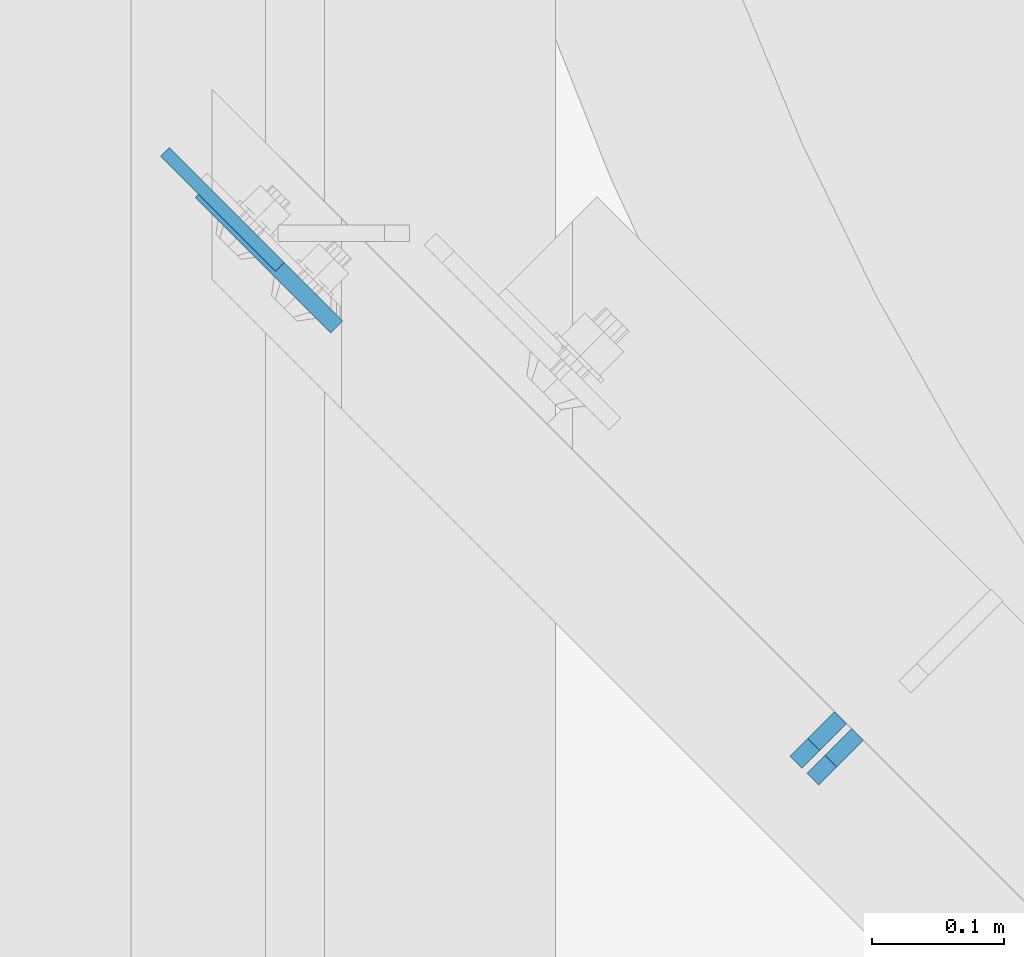
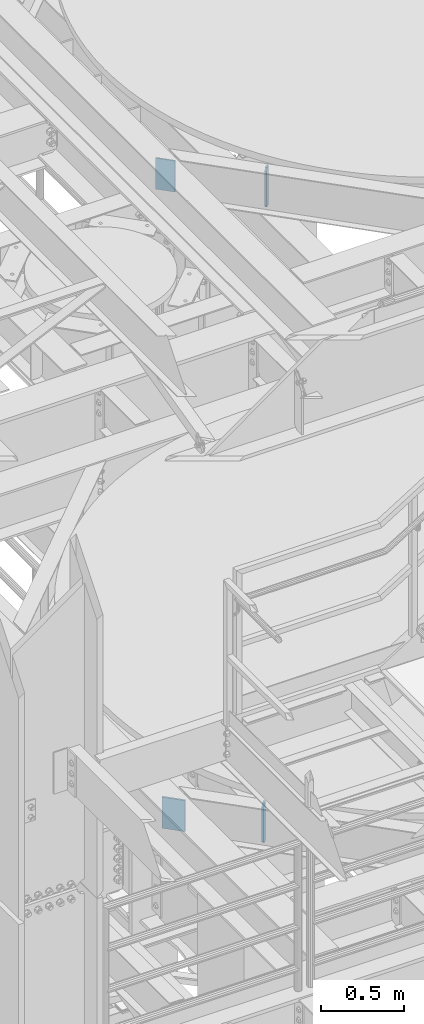
# One storey, part 1491 of 1876: 4 plates, 4 elements without a shape of their own.
"""IFC2X3 building model written with IfcOpenShell, lengths in millimetres."""

from ifc_helpers import new_model, si_unit, frame, origin_with_axes, place, context, subcontext, project, spatial, faceted_brep, material, type_object, element, aggregate, save


model = new_model("IFC2X3")

# Units and contexts
model_context = context("Model", 3, precision=1e-05, world=origin_with_axes())
body_context = subcontext(model_context, "Body", "Model", "MODEL_VIEW")
ifc_project = project(units=[si_unit("LENGTHUNIT", "METRE", prefix="MILLI"), si_unit("AREAUNIT", "SQUARE_METRE"), si_unit("VOLUMEUNIT", "CUBIC_METRE"), si_unit("MASSUNIT", "GRAM", prefix="KILO"), si_unit("TIMEUNIT", "SECOND"), si_unit("PLANEANGLEUNIT", "RADIAN"), si_unit("SOLIDANGLEUNIT", "STERADIAN"), si_unit("THERMODYNAMICTEMPERATUREUNIT", "DEGREE_CELSIUS"), si_unit("LUMINOUSINTENSITYUNIT", "LUMEN")], contexts=[model_context])

# Site, building, storey
site_placement = place(None, origin_with_axes())
site = spatial("IfcSite", under=ifc_project, at=site_placement, CompositionType="ELEMENT")
building_placement = place(site_placement, origin_with_axes())
building = spatial("IfcBuilding", under=site, at=building_placement, Name="Undefined", CompositionType="ELEMENT")
storey_placement = place(building_placement, origin_with_axes())
storey = spatial("IfcBuildingStorey", under=building, at=storey_placement, Name="Undefined", CompositionType="ELEMENT", Elevation=0.0)

# Assembly, plate
assembly_1_placement = place(storey_placement, origin_with_axes())
assembly_1 = element("IfcElementAssembly", 1, at=assembly_1_placement, inside=storey, Name="BEAM", AssemblyPlace="NOTDEFINED", PredefinedType="RIGID_FRAME")
ifc_material = material(Name="STEEL/A36")
plate_type_1 = type_object("IfcPlateType", PredefinedType="NOTDEFINED")
plate_1_placement = place(assembly_1_placement, frame((2006.79248256834, -2398.75971339006, 17945.1), z_axis=(0.707106781186547, -0.707106781186548, 0.0), x_axis=(0.0, 0.0, -1.0)))
plate_1 = element("IfcPlate", 2, at=plate_1_placement, type_object=plate_type_1, material=ifc_material, Name="PLATE", context=body_context, shape_type="Brep", body=[
    faceted_brep([(0.0, -4.76249999999982, 0.0), (0.0, -4.76249999998612, 122.735511779807), (0.0, 4.76250000001534, 122.735511779805), (0.0, 4.76249999999982, 0.0), (228.600006103516, -4.76249999998612, 122.735511779807), (228.600006103516, 4.76250000001534, 122.735511779805), (228.600006103516, -4.76250000000073, 0.0), (228.600006103516, 4.76250000000073, 0.0)], [[[0, 1, 2, 3]], [[1, 4, 5, 2]], [[4, 6, 7, 5]], [[6, 0, 3, 7]], [[5, 7, 3, 2]], [[6, 4, 1, 0]]]),
])
aggregate(assembly_1, [plate_1])

assembly_2_placement = place(storey_placement, origin_with_axes())
assembly_2 = element("IfcElementAssembly", 3, at=assembly_2_placement, inside=storey, Name="BEAM", AssemblyPlace="NOTDEFINED", PredefinedType="RIGID_FRAME")
plate_type_2 = type_object("IfcPlateType", PredefinedType="NOTDEFINED")
plate_2_placement = place(assembly_2_placement, frame((2496.30584223178, -2872.5576358077, 17684.75), z_axis=(0.0, 0.0, 1.0), x_axis=(0.707106781186548, 0.707106781186547, 0.0)))
plate_2 = element("IfcPlate", 4, at=plate_2_placement, type_object=plate_type_2, material=ifc_material, Name="PLATE", context=body_context, shape_type="Brep", body=[
    faceted_brep([(0.0, -6.35000000000196, 19.0499992370605), (9.09494701772928e-13, -6.34999999999832, 273.050006866455), (-2.72848410531878e-12, 6.34999999999923, 273.050006866455), (0.0, 6.35000000000105, 19.0499992370605), (19.0499992370578, -6.35000000000696, 292.100006103516), (19.049999237056, 6.3499999999915, 292.100006103516), (47.6249999999927, -6.3500000000206, 292.100006103516), (47.62499999999, 6.34999999997831, 292.100006103516), (47.6249999999927, -6.3500000000206, 3.63797880709171e-12), (47.62499999999, 6.34999999997831, 3.63797880709171e-12), (19.0499992370642, -6.35000000000105, 0.0), (19.0499992370633, 6.35000000000105, 0.0)], [[[0, 1, 2, 3]], [[1, 4, 5, 2]], [[4, 6, 7, 5]], [[6, 8, 9, 7]], [[8, 10, 11, 9]], [[10, 0, 3, 11]], [[5, 7, 9, 11, 3, 2]], [[10, 8, 6, 4, 1, 0]]]),
])
aggregate(assembly_2, [plate_2])

assembly_3_placement = place(storey_placement, origin_with_axes())
assembly_3 = element("IfcElementAssembly", 5, at=assembly_3_placement, inside=storey, Name="BEAM", AssemblyPlace="NOTDEFINED", PredefinedType="RIGID_FRAME")
plate_3_placement = place(assembly_3_placement, frame((2483.47836659859, -2859.98572200222, 13011.15), z_axis=(0.0, 0.0, 1.0), x_axis=(0.707106781186548, 0.707106781186547, 0.0)))
plate_3 = element("IfcPlate", 6, at=plate_3_placement, type_object=plate_type_2, material=ifc_material, Name="PLATE", context=body_context, shape_type="Brep", body=[
    faceted_brep([(0.0, -6.35000000000196, 19.0499992370605), (9.09494701772928e-13, -6.34999999999832, 273.050006866455), (-2.72848410531878e-12, 6.34999999999923, 273.050006866455), (0.0, 6.35000000000105, 19.0499992370605), (19.0499992370578, -6.35000000000696, 292.100006103516), (19.049999237056, 6.3499999999915, 292.100006103516), (47.6249999999927, -6.3500000000206, 292.100006103516), (47.62499999999, 6.34999999997831, 292.100006103516), (47.6249999999927, -6.3500000000206, 3.63797880709171e-12), (47.62499999999, 6.34999999997831, 3.63797880709171e-12), (19.0499992370642, -6.35000000000105, 0.0), (19.0499992370633, 6.35000000000105, 0.0)], [[[0, 1, 2, 3]], [[1, 4, 5, 2]], [[4, 6, 7, 5]], [[6, 8, 9, 7]], [[8, 10, 11, 9]], [[10, 0, 3, 11]], [[5, 7, 9, 11, 3, 2]], [[10, 8, 6, 4, 1, 0]]]),
])
aggregate(assembly_3, [plate_3])

assembly_4_placement = place(storey_placement, origin_with_axes())
assembly_4 = element("IfcElementAssembly", 7, at=assembly_4_placement, inside=storey, Name="BEAM", AssemblyPlace="NOTDEFINED", PredefinedType="RIGID_FRAME")
plate_type_3 = type_object("IfcPlateType", PredefinedType="NOTDEFINED")
plate_4_placement = place(assembly_4_placement, frame((2034.10915829908, -2428.57715175079, 13258.8), z_axis=(0.707106781186547, -0.707106781186548, 0.0), x_axis=(0.0, 0.0, -1.0)))
plate_4 = element("IfcPlate", 8, at=plate_4_placement, type_object=plate_type_3, material=ifc_material, Name="PLATE", context=body_context, shape_type="Brep", body=[
    faceted_brep([(0.0, -6.35000000000036, 0.0), (0.0, -6.35000000006039, 144.960510253931), (0.0, 6.34999999993761, 144.960510253933), (0.0, 6.35000000000036, 0.0), (228.600006103516, -6.35000000006039, 144.960510253931), (228.600006103516, 6.34999999993761, 144.960510253933), (228.600006103516, -6.34999999999854, 0.0), (228.600006103516, 6.34999999999854, 0.0)], [[[0, 1, 2, 3]], [[1, 4, 5, 2]], [[4, 6, 7, 5]], [[6, 0, 3, 7]], [[5, 7, 3, 2]], [[6, 4, 1, 0]]]),
])
aggregate(assembly_4, [plate_4])

save(model, "model.ifc")
